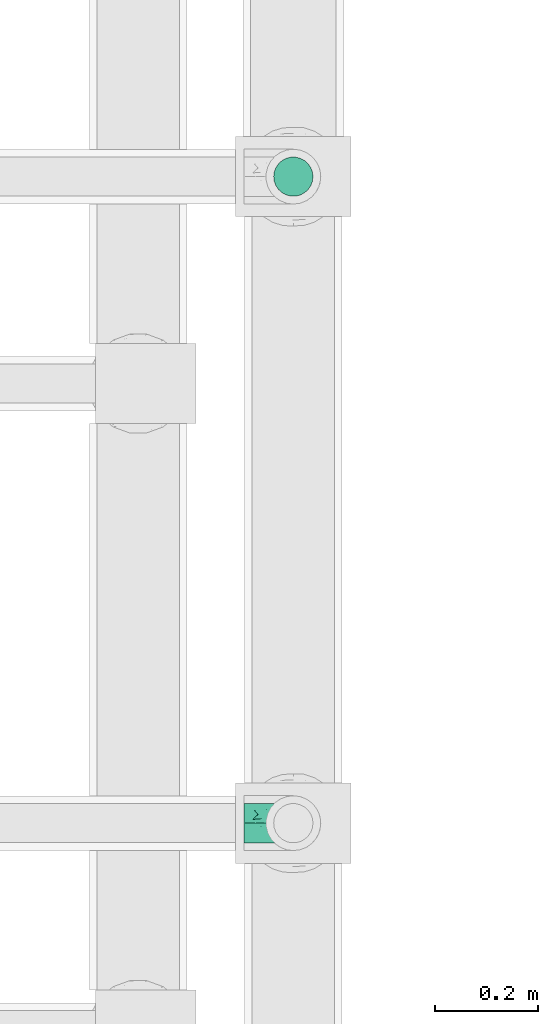
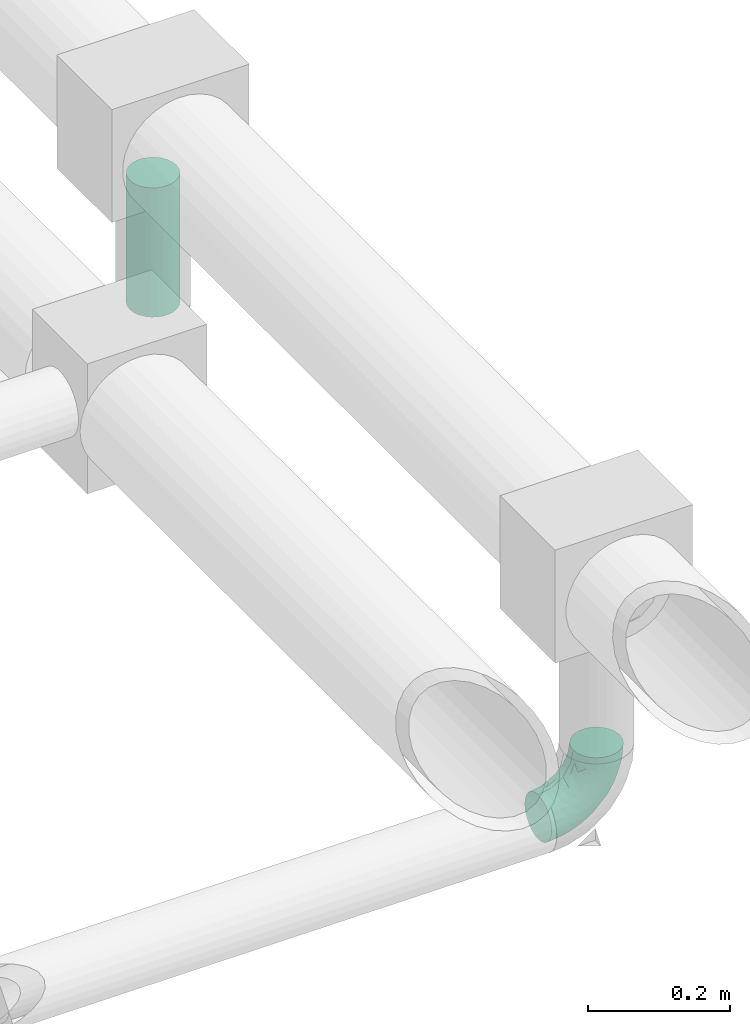
# One storey, part 620 of 827: 1 flow fitting, 1 flow segment.
"""IFC2X3 building model written with IfcOpenShell, lengths in millimetres."""

from ifc_helpers import new_model, entity, si_unit, converted_unit, derived_unit, direction, frame, origin, origin_2d_with_axis, place, context, subcontext, project, spatial, circle, extrude, faceted_brep, source, transform, mapped, material, type_object, type_shapes, element, save


model = new_model("IFC2X3")

# Units and contexts
model_context = context("Model", 3, precision=0.01, world=origin(), true_north=direction((6.12303176911189e-17, 1.0)))
body_context = subcontext(model_context, "Body", "Model", "MODEL_VIEW")
ifc_project = project(units=[si_unit("LENGTHUNIT", "METRE", prefix="MILLI"), si_unit("AREAUNIT", "SQUARE_METRE"), si_unit("VOLUMEUNIT", "CUBIC_METRE"), converted_unit("PLANEANGLEUNIT", "DEGREE", entity("IfcRatioMeasure", 0.0174532925199433), si_unit("PLANEANGLEUNIT", "RADIAN"), dimensions=[0, 0, 0, 0, 0, 0, 0]), si_unit("MASSUNIT", "GRAM", prefix="KILO"), derived_unit("MASSDENSITYUNIT", [(si_unit("MASSUNIT", "GRAM", prefix="KILO"), 1), (si_unit("LENGTHUNIT", "METRE"), -3)]), derived_unit("MOMENTOFINERTIAUNIT", [(si_unit("LENGTHUNIT", "METRE"), 4)]), si_unit("TIMEUNIT", "SECOND"), si_unit("FREQUENCYUNIT", "HERTZ"), si_unit("THERMODYNAMICTEMPERATUREUNIT", "DEGREE_CELSIUS"), derived_unit("THERMALTRANSMITTANCEUNIT", [(si_unit("MASSUNIT", "GRAM", prefix="KILO"), 1), (si_unit("THERMODYNAMICTEMPERATUREUNIT", "KELVIN"), -1), (si_unit("TIMEUNIT", "SECOND"), -3)]), derived_unit("VOLUMETRICFLOWRATEUNIT", [(si_unit("LENGTHUNIT", "METRE"), 3), (si_unit("TIMEUNIT", "SECOND"), -1)]), derived_unit("MASSFLOWRATEUNIT", [(si_unit("MASSUNIT", "GRAM", prefix="KILO"), 1), (si_unit("TIMEUNIT", "SECOND"), -1)]), derived_unit("ROTATIONALFREQUENCYUNIT", [(si_unit("TIMEUNIT", "SECOND"), -1)]), si_unit("ELECTRICCURRENTUNIT", "AMPERE"), si_unit("ELECTRICVOLTAGEUNIT", "VOLT"), si_unit("POWERUNIT", "WATT"), si_unit("FORCEUNIT", "NEWTON", prefix="KILO"), si_unit("ILLUMINANCEUNIT", "LUX"), si_unit("LUMINOUSFLUXUNIT", "LUMEN"), si_unit("LUMINOUSINTENSITYUNIT", "CANDELA"), derived_unit("USERDEFINED", [(si_unit("MASSUNIT", "GRAM", prefix="KILO"), -1), (si_unit("LENGTHUNIT", "METRE"), -2), (si_unit("TIMEUNIT", "SECOND"), 3), (si_unit("LUMINOUSFLUXUNIT", "LUMEN"), 1)]), derived_unit("LINEARVELOCITYUNIT", [(si_unit("LENGTHUNIT", "METRE"), 1), (si_unit("TIMEUNIT", "SECOND"), -1)]), si_unit("PRESSUREUNIT", "PASCAL"), derived_unit("USERDEFINED", [(si_unit("LENGTHUNIT", "METRE"), -2), (si_unit("MASSUNIT", "GRAM", prefix="KILO"), 1), (si_unit("TIMEUNIT", "SECOND"), -2)]), derived_unit("LINEARFORCEUNIT", [(si_unit("MASSUNIT", "GRAM", prefix="KILO"), 1), (si_unit("LENGTHUNIT", "METRE"), 1), (si_unit("TIMEUNIT", "SECOND"), -2), (si_unit("LENGTHUNIT", "METRE"), -1)]), derived_unit("PLANARFORCEUNIT", [(si_unit("MASSUNIT", "GRAM", prefix="KILO"), 1), (si_unit("LENGTHUNIT", "METRE"), 1), (si_unit("TIMEUNIT", "SECOND"), -2), (si_unit("LENGTHUNIT", "METRE"), -2)])], contexts=[model_context])

# Site, building, storey
site_placement = place(None, origin())
site = spatial("IfcSite", under=ifc_project, at=site_placement, CompositionType="ELEMENT")
building_placement = place(site_placement, origin())
building = spatial("IfcBuilding", under=site, at=building_placement, CompositionType="ELEMENT")
storey_placement = place(building_placement, frame((0.0, 0.0, 28200.0)))
storey = spatial("IfcBuildingStorey", under=building, at=storey_placement, Name="08", CompositionType="ELEMENT", Elevation=28200.0)

# Flow segment
pipe_segment_type = type_object("IfcPipeSegmentType", PredefinedType="NOTDEFINED")
flow_segment_placement = place(storey_placement, frame((38008.7, 11690.61, 2695.0)))
element("IfcFlowSegment", 1, at=flow_segment_placement, inside=storey, type_object=pipe_segment_type, context=body_context, shape_type="SweptSolid", body=[
    extrude(circle(Radius=38.0, at=origin_2d_with_axis()), frame((39.6, 39.6, 0.0)), (0.0, 0.0, 1.0), 222.499999999993),
])

# Flow fitting
ifc_material = material()
pipe_fitting_type = type_object("IfcPipeFittingType", Name="ADSK_1", PredefinedType="NOTDEFINED", material=ifc_material)
shared_shape = source(origin(), body_context, "Body", "Brep", [
    faceted_brep([(-95.0, 19.02, -32.95), (-95.0, 9.85, -36.75), (-95.0, 0.0, -38.05), (-95.0, -9.85, -36.75), (-95.0, -19.03, -32.95), (-95.0, -26.91, -26.91), (-95.0, -32.95, -19.03), (-95.0, -36.75, -9.85), (-95.0, -38.05, 0.0), (-95.0, -36.75, 9.85), (-95.0, -32.95, 19.02), (-95.0, -26.91, 26.91), (-95.0, -19.03, 32.95), (-95.0, -9.85, 36.75), (-95.0, 0.0, 38.05), (-95.0, 9.85, 36.75), (-95.0, 19.02, 32.95), (-95.0, 26.91, 26.91), (-95.0, 32.95, 19.02), (-95.0, 36.75, 9.85), (-95.0, 38.05, 0.0), (-95.0, 36.75, -9.85), (-95.0, 32.95, -19.03), (-95.0, 26.91, -26.91), (0.0, 95.0, -38.05), (-9.85, 95.0, -36.75), (-19.02, 95.0, -32.95), (-26.91, 95.0, -26.91), (-32.95, 95.0, -19.03), (-36.75, 95.0, -9.85), (-38.05, 95.0, 0.0), (-36.75, 95.0, 9.85), (-32.95, 95.0, 19.02), (-26.91, 95.0, 26.91), (-19.02, 95.0, 32.95), (-9.85, 95.0, 36.75), (0.0, 95.0, 38.05), (9.85, 95.0, 36.75), (19.03, 95.0, 32.95), (26.91, 95.0, 26.91), (32.95, 95.0, 19.02), (36.75, 95.0, 9.85), (38.05, 95.0, 0.0), (36.75, 95.0, -9.85), (32.95, 95.0, -19.03), (26.91, 95.0, -26.91), (19.03, 95.0, -32.95), (9.85, 95.0, -36.75), (-7.99, -4.96, 6.3), (-0.92, 0.92, 0.0), (4.62, 8.1, 8.01), (-76.19, -35.57, 0.0), (-64.32, -32.32, 12.43), (20.51, 62.45, 28.68), (-60.56, -33.52, 0.0), (-70.4, -13.47, 34.42), (-39.61, -5.88, 32.32), (-49.6, 2.07, 37.1), (-70.34, -28.81, 21.71), (14.64, 40.81, 26.5), (5.88, 39.61, 32.32), (3.59, 20.77, 25.31), (-40.45, 68.06, 16.75), (-62.45, -20.51, 28.68), (-44.52, -26.87, 0.0), (-28.47, -20.22, 0.0), (-26.43, -17.83, 8.75), (-76.1, 39.63, 10.76), (-72.74, 37.58, 18.19), (-60.35, 46.18, 14.61), (-13.4, 13.4, 32.12), (-20.77, -3.59, 25.31), (-14.66, 81.47, 35.56), (-6.22, 71.26, 37.92), (-57.5, 42.48, 22.79), (-15.0, 34.74, 37.7), (-27.1, 12.08, 36.05), (-9.2, 28.81, 35.63), (-79.98, 23.7, 30.95), (-73.68, -4.3, 37.48), (-30.74, 21.67, 37.97), (-62.36, 47.59, 6.79), (-72.71, 32.83, 24.69), (-67.42, 7.02, 37.95), (-32.13, 75.27, 24.51), (-43.46, 51.47, 26.26), (-24.98, 73.15, 31.29), (20.59, 41.28, 19.85), (7.79, 16.09, 15.86), (-73.21, 42.39, 0.0), (-54.73, 54.73, 0.0), (-73.44, 15.79, 35.79), (-5.94, 4.32, 20.43), (28.81, 70.34, 21.71), (32.32, 64.32, 12.43), (-53.59, 26.2, 35.09), (-52.02, 19.31, 37.21), (21.38, 33.53, 10.34), (26.87, 44.52, 0.0), (-48.28, 12.14, 38.05), (4.3, 73.68, 37.48), (-44.08, -25.52, 12.79), (-41.28, -20.59, 19.85), (35.57, 76.19, 0.0), (-47.26, 54.3, 20.18), (-47.4, 61.99, 8.58), (-42.39, 73.21, 0.0), (-39.67, 78.86, 7.21), (-45.69, 36.84, 33.11), (-32.83, 50.13, 33.35), (13.47, 70.4, 34.42), (-18.25, 63.73, 36.07), (-40.63, -13.75, 27.22), (-16.63, 46.37, 37.95), (-53.47, 38.79, 28.59), (-26.07, 48.54, 36.15), (-34.51, 34.51, 36.86), (-2.07, 49.6, 37.1), (-22.79, -10.49, 19.23), (-61.73, 28.67, 31.87), (9.65, 14.7, 0.0), (20.22, 28.47, 0.0), (33.52, 60.56, 0.0), (-11.42, -5.44, 13.25), (-14.7, -9.65, 0.0), (-81.47, 14.66, -35.56), (-62.45, -20.51, -28.68), (-71.26, 6.22, -37.92), (-75.27, 32.13, -24.51), (-73.15, 24.98, -31.29), (13.47, 70.4, -34.42), (5.88, 39.61, -32.32), (-2.07, 49.6, -37.1), (-78.86, 39.67, -7.21), (-70.4, -13.47, -34.42), (-39.61, -5.88, -32.32), (-61.99, 47.4, -8.58), (32.32, 64.32, -12.43), (28.81, 70.34, -21.71), (-63.73, 18.25, -36.07), (-50.13, 32.83, -33.35), (4.3, 73.68, -37.48), (-7.02, 67.42, -37.95), (-39.63, 76.1, -10.76), (-46.18, 60.35, -14.61), (-47.59, 62.36, -6.79), (-64.32, -32.32, -12.43), (-26.2, 53.59, -35.09), (-15.79, 73.44, -35.79), (-19.31, 52.02, -37.21), (-37.58, 72.74, -18.19), (-70.34, -28.81, -21.71), (-42.48, 57.5, -22.79), (-38.79, 53.47, -28.59), (-51.47, 43.46, -26.26), (-32.83, 72.71, -24.69), (-46.37, 16.63, -37.95), (-73.68, -4.3, -37.48), (-41.28, -20.59, -19.85), (-44.08, -25.52, -12.79), (13.75, 40.63, -27.22), (20.51, 62.45, -28.68), (-68.06, 40.45, -16.75), (-54.3, 47.26, -20.18), (-12.14, 48.28, -38.05), (-21.67, 30.74, -37.97), (-36.84, 45.69, -33.11), (-11.42, -5.44, -13.25), (7.79, 16.09, -15.86), (4.62, 8.1, -8.01), (-23.7, 79.98, -30.95), (-26.43, -17.83, -8.75), (-7.99, -4.96, -6.3), (-40.81, -14.64, -26.5), (-20.77, -3.59, -25.31), (-34.74, 15.0, -37.7), (-12.08, 27.1, -36.05), (-28.81, 9.2, -35.63), (-22.79, -10.49, -19.23), (21.38, 33.53, -10.34), (20.59, 41.28, -19.85), (-48.54, 26.07, -36.15), (-49.6, 2.07, -37.1), (-13.4, 13.4, -32.12), (3.59, 20.77, -25.31), (-28.67, 61.73, -31.87), (-34.51, 34.51, -36.86), (-5.94, 4.32, -20.43)], [[[0, 1, 2, 3, 4, 5, 6, 7, 8, 9, 10, 11, 12, 13, 14, 15, 16, 17, 18, 19, 20, 21, 22, 23]], [[24, 25, 26, 27, 28, 29, 30, 31, 32, 33, 34, 35, 36, 37, 38, 39, 40, 41, 42, 43, 44, 45, 46, 47]], [[48, 49, 50]], [[51, 52, 9]], [[53, 39, 38]], [[9, 52, 10]], [[54, 52, 51]], [[55, 56, 57]], [[11, 10, 58]], [[59, 60, 61]], [[32, 31, 62]], [[63, 12, 11]], [[63, 55, 12]], [[64, 65, 66]], [[67, 68, 69]], [[70, 56, 71]], [[35, 72, 73]], [[69, 68, 74]], [[75, 76, 77]], [[16, 78, 17]], [[13, 79, 14]], [[76, 75, 80]], [[67, 69, 81]], [[18, 17, 82]], [[14, 79, 83]], [[20, 19, 67]], [[84, 85, 86]], [[87, 61, 88]], [[89, 81, 90]], [[18, 82, 68]], [[15, 91, 16]], [[14, 83, 15]], [[71, 92, 61]], [[17, 78, 82]], [[93, 87, 94]], [[95, 91, 96]], [[97, 98, 94]], [[86, 72, 34]], [[96, 99, 80]], [[37, 36, 100]], [[40, 39, 93]], [[40, 94, 41]], [[64, 66, 101]], [[93, 94, 40]], [[58, 102, 63]], [[94, 103, 41]], [[94, 87, 97]], [[104, 69, 74]], [[34, 33, 86]], [[105, 69, 104]], [[52, 58, 10]], [[106, 107, 30]], [[108, 109, 85]], [[105, 106, 90]], [[53, 110, 60]], [[86, 111, 72]], [[86, 109, 111]], [[33, 84, 86]], [[12, 55, 13]], [[112, 56, 63]], [[110, 38, 37]], [[34, 72, 35]], [[36, 35, 73]], [[111, 113, 73]], [[105, 107, 106]], [[110, 53, 38]], [[74, 114, 85]], [[91, 15, 83]], [[105, 90, 81]], [[107, 62, 31]], [[33, 32, 84]], [[115, 109, 116]], [[111, 115, 113]], [[100, 73, 117]], [[56, 55, 63]], [[79, 55, 57]], [[102, 118, 112]], [[56, 70, 76]], [[100, 110, 37]], [[117, 77, 60]], [[117, 60, 110]], [[60, 70, 61]], [[58, 52, 101]], [[63, 11, 58]], [[39, 53, 93]], [[87, 93, 53]], [[96, 91, 83]], [[78, 91, 119]], [[32, 62, 84]], [[84, 62, 104]], [[86, 85, 109]], [[85, 114, 108]], [[80, 113, 116]], [[117, 73, 113]], [[80, 116, 96]], [[80, 57, 76]], [[71, 112, 118]], [[61, 87, 59]], [[62, 107, 105]], [[97, 120, 121]], [[70, 71, 61]], [[71, 118, 92]], [[73, 100, 36]], [[110, 100, 117]], [[55, 79, 13]], [[83, 79, 57]], [[96, 83, 99]], [[116, 108, 95]], [[50, 97, 88]], [[97, 87, 88]], [[50, 49, 120]], [[122, 94, 98]], [[89, 20, 67]], [[105, 81, 69]], [[89, 67, 81]], [[68, 19, 18]], [[68, 67, 19]], [[74, 68, 82]], [[114, 82, 119]], [[74, 85, 104]], [[82, 114, 74]], [[114, 119, 108]], [[95, 108, 119]], [[116, 109, 108]], [[123, 48, 50]], [[97, 50, 120]], [[123, 50, 88]], [[91, 95, 119]], [[116, 95, 96]], [[84, 104, 85]], [[104, 62, 105]], [[83, 57, 99]], [[57, 80, 99]], [[66, 48, 123]], [[66, 124, 48]], [[118, 66, 123]], [[124, 66, 65]], [[66, 118, 101]], [[54, 64, 52]], [[124, 49, 48]], [[30, 107, 31]], [[91, 78, 16]], [[82, 78, 119]], [[56, 76, 57]], [[77, 76, 70]], [[60, 77, 70]], [[77, 117, 75]], [[117, 113, 75]], [[113, 80, 75]], [[9, 8, 51]], [[103, 94, 122]], [[103, 42, 41]], [[73, 72, 111]], [[113, 115, 116]], [[111, 109, 115]], [[102, 112, 63]], [[71, 56, 112]], [[118, 102, 101]], [[92, 123, 88]], [[123, 92, 118]], [[61, 92, 88]], [[87, 53, 59]], [[60, 59, 53]], [[97, 121, 98]], [[58, 101, 102]], [[64, 101, 52]], [[125, 1, 0]], [[126, 5, 4]], [[2, 1, 127]], [[1, 125, 127]], [[128, 129, 23]], [[130, 131, 132]], [[89, 133, 20]], [[126, 134, 135]], [[136, 89, 90]], [[137, 138, 44]], [[139, 129, 140]], [[24, 141, 142]], [[143, 144, 145]], [[125, 129, 139]], [[6, 146, 7]], [[147, 148, 149]], [[146, 51, 7]], [[143, 150, 144]], [[146, 6, 151]], [[152, 153, 154]], [[126, 4, 134]], [[0, 23, 129]], [[28, 155, 150]], [[43, 42, 103]], [[54, 146, 64]], [[139, 156, 127]], [[157, 3, 2]], [[151, 158, 159]], [[160, 131, 161]], [[22, 21, 162]], [[136, 144, 163]], [[149, 164, 165]], [[24, 142, 25]], [[166, 140, 154]], [[154, 129, 128]], [[143, 30, 29]], [[167, 168, 169]], [[155, 28, 27]], [[26, 170, 27]], [[171, 167, 172]], [[26, 25, 148]], [[27, 170, 155]], [[173, 135, 174]], [[144, 150, 152]], [[175, 176, 177]], [[24, 47, 141]], [[45, 161, 46]], [[148, 25, 142]], [[176, 175, 165]], [[64, 159, 171]], [[138, 45, 44]], [[130, 46, 161]], [[137, 44, 43]], [[178, 159, 158]], [[137, 103, 122]], [[163, 144, 152]], [[136, 133, 89]], [[103, 137, 43]], [[6, 5, 151]], [[178, 158, 173]], [[134, 4, 3]], [[178, 173, 174]], [[137, 98, 179]], [[145, 90, 106]], [[138, 180, 161]], [[46, 130, 47]], [[136, 90, 145]], [[133, 162, 21]], [[23, 22, 128]], [[139, 140, 181]], [[139, 181, 156]], [[157, 127, 182]], [[157, 134, 3]], [[182, 177, 135]], [[182, 135, 134]], [[135, 183, 174]], [[131, 130, 161]], [[141, 130, 132]], [[160, 180, 184]], [[131, 183, 176]], [[5, 126, 151]], [[158, 151, 126]], [[180, 138, 137]], [[161, 45, 138]], [[149, 148, 142]], [[170, 148, 185]], [[22, 162, 128]], [[128, 162, 163]], [[129, 154, 140]], [[154, 153, 166]], [[165, 156, 186]], [[182, 127, 156]], [[165, 186, 149]], [[165, 132, 176]], [[131, 184, 183]], [[187, 167, 178]], [[184, 168, 187]], [[167, 169, 172]], [[184, 180, 168]], [[174, 183, 184]], [[127, 157, 2]], [[134, 157, 182]], [[130, 141, 47]], [[142, 141, 132]], [[149, 142, 164]], [[186, 166, 147]], [[180, 179, 168]], [[169, 179, 120]], [[137, 179, 180]], [[179, 121, 120]], [[106, 30, 143]], [[136, 145, 144]], [[106, 143, 145]], [[150, 29, 28]], [[150, 143, 29]], [[152, 150, 155]], [[153, 155, 185]], [[152, 154, 163]], [[155, 153, 152]], [[153, 185, 166]], [[147, 166, 185]], [[186, 140, 166]], [[169, 120, 49]], [[169, 49, 172]], [[179, 169, 168]], [[148, 147, 185]], [[186, 147, 149]], [[128, 163, 154]], [[163, 162, 136]], [[142, 132, 164]], [[132, 165, 164]], [[171, 124, 65]], [[124, 171, 172]], [[64, 146, 159]], [[171, 159, 178]], [[171, 65, 64]], [[172, 49, 124]], [[162, 133, 136]], [[20, 133, 21]], [[148, 170, 26]], [[155, 170, 185]], [[131, 176, 132]], [[177, 176, 183]], [[135, 177, 183]], [[177, 182, 175]], [[182, 156, 175]], [[156, 165, 175]], [[51, 146, 54]], [[51, 8, 7]], [[129, 125, 0]], [[127, 125, 139]], [[140, 186, 181]], [[156, 181, 186]], [[158, 126, 173]], [[135, 173, 126]], [[187, 178, 174]], [[171, 178, 167]], [[184, 187, 174]], [[167, 187, 168]], [[180, 160, 161]], [[184, 131, 160]], [[98, 137, 122]], [[98, 121, 179]], [[151, 159, 146]]]),
])
type_shapes(pipe_fitting_type, [shared_shape])
flow_fitting_placement = place(storey_placement, frame((38048.3, 10480.2, 2600.0), z_axis=(0.0, 1.0, 0.0), x_axis=(0.0, 0.0, -1.0)))
element("IfcFlowFitting", 2, at=flow_fitting_placement, inside=storey, type_object=pipe_fitting_type, material=ifc_material, Name="ADSK_1", ObjectType="ADSK_1", context=body_context, shape_type="MappedRepresentation", body=[
    mapped(shared_shape, transform((0.0, 0.0, 0.0), scale=1.0)),
])

save(model, "model.ifc")
